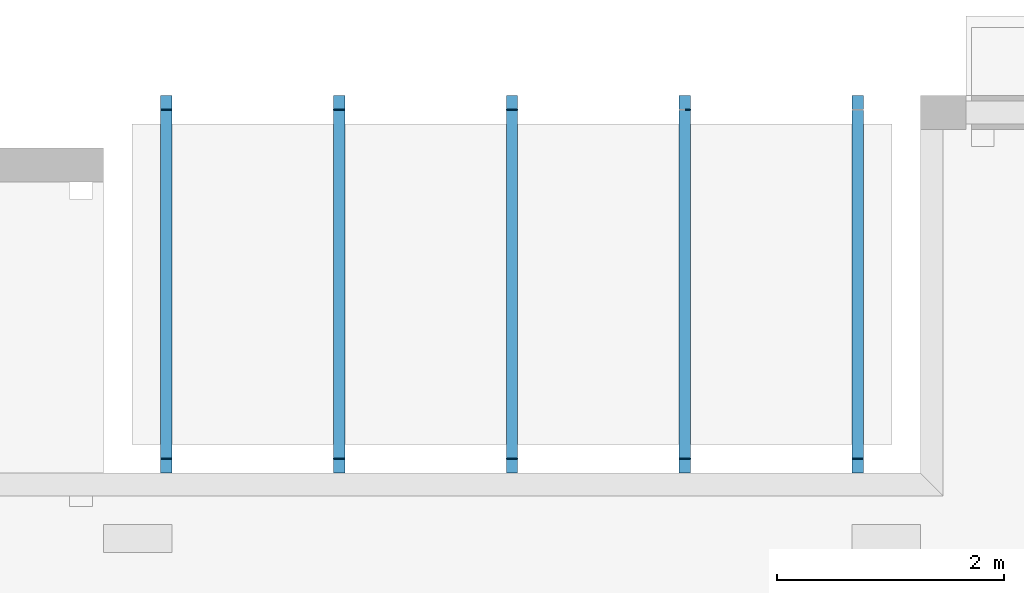
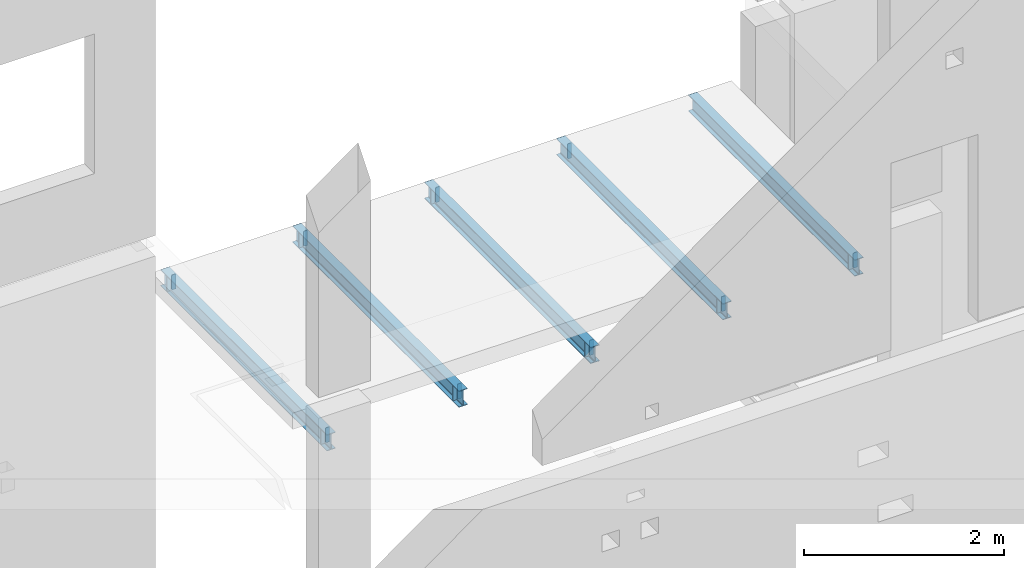
# One storey, part 5 of 7: 22 beams.
"""IFC2X3 building model written with IfcOpenShell, lengths in millimetres."""

from ifc_helpers import new_model, entity, si_unit, converted_unit, derived_unit, money_unit, direction, frame, origin_with_axes, place, context, subcontext, project, spatial, faceted_brep, material, type_object, element, save


model = new_model("IFC2X3")

# Units and contexts
model_context = context("Model", 3, precision=1e-05, world=origin_with_axes(), true_north=direction((0.0, 1.0)))
body_context = subcontext(model_context, "Body", "Model", "MODEL_VIEW", scale=1.0)
ifc_project = project(units=[si_unit("LENGTHUNIT", "METRE", prefix="MILLI"), si_unit("AREAUNIT", "SQUARE_METRE"), si_unit("VOLUMEUNIT", "CUBIC_METRE"), si_unit("ABSORBEDDOSEUNIT", "GRAY"), si_unit("AMOUNTOFSUBSTANCEUNIT", "MOLE"), si_unit("DOSEEQUIVALENTUNIT", "SIEVERT"), si_unit("ELECTRICCAPACITANCEUNIT", "FARAD"), si_unit("ELECTRICCHARGEUNIT", "COULOMB"), si_unit("ELECTRICCONDUCTANCEUNIT", "SIEMENS"), si_unit("ELECTRICCURRENTUNIT", "AMPERE"), si_unit("ELECTRICRESISTANCEUNIT", "OHM"), si_unit("ELECTRICVOLTAGEUNIT", "VOLT"), si_unit("ENERGYUNIT", "JOULE"), si_unit("FORCEUNIT", "NEWTON"), si_unit("FREQUENCYUNIT", "HERTZ"), si_unit("ILLUMINANCEUNIT", "LUX"), si_unit("INDUCTANCEUNIT", "HENRY"), si_unit("LUMINOUSFLUXUNIT", "LUMEN"), si_unit("LUMINOUSINTENSITYUNIT", "CANDELA"), si_unit("MAGNETICFLUXDENSITYUNIT", "TESLA"), si_unit("MAGNETICFLUXUNIT", "WEBER"), si_unit("MASSUNIT", "GRAM"), converted_unit("PLANEANGLEUNIT", "degree", entity("IfcReal", 0.0174532925199433), si_unit("PLANEANGLEUNIT", "RADIAN"), dimensions=[0, 0, 0, 0, 0, 0, 0]), si_unit("POWERUNIT", "WATT"), si_unit("PRESSUREUNIT", "PASCAL"), si_unit("RADIOACTIVITYUNIT", "BECQUEREL"), si_unit("SOLIDANGLEUNIT", "STERADIAN"), si_unit("THERMODYNAMICTEMPERATUREUNIT", "KELVIN"), si_unit("TIMEUNIT", "SECOND"), derived_unit("ACCELERATIONUNIT", [(si_unit("LENGTHUNIT", "METRE", prefix="MILLI"), 1), (si_unit("TIMEUNIT", "SECOND"), -2)]), derived_unit("ANGULARVELOCITYUNIT", [(converted_unit("PLANEANGLEUNIT", "degree", entity("IfcReal", 0.0174532925199433), si_unit("PLANEANGLEUNIT", "RADIAN"), dimensions=[0, 0, 0, 0, 0, 0, 0]), 1), (si_unit("TIMEUNIT", "SECOND"), -1)]), derived_unit("CURVATUREUNIT", [(converted_unit("PLANEANGLEUNIT", "degree", entity("IfcReal", 0.0174532925199433), si_unit("PLANEANGLEUNIT", "RADIAN"), dimensions=[0, 0, 0, 0, 0, 0, 0]), 1), (si_unit("LENGTHUNIT", "METRE", prefix="MILLI"), -1)]), derived_unit("DYNAMICVISCOSITYUNIT", [(si_unit("PRESSUREUNIT", "PASCAL"), 1), (si_unit("TIMEUNIT", "SECOND"), 1)]), derived_unit("HEATFLUXDENSITYUNIT", [(si_unit("POWERUNIT", "WATT"), 1), (si_unit("LENGTHUNIT", "METRE", prefix="MILLI"), -2)]), derived_unit("HEATINGVALUEUNIT", [(si_unit("ENERGYUNIT", "JOULE"), 1), (si_unit("MASSUNIT", "GRAM"), -1)]), derived_unit("INTEGERCOUNTRATEUNIT", [(si_unit("TIMEUNIT", "SECOND"), -1)]), derived_unit("IONCONCENTRATIONUNIT", [(si_unit("MASSUNIT", "GRAM"), 1), (si_unit("VOLUMEUNIT", "CUBIC_METRE"), -1)]), derived_unit("ISOTHERMALMOISTURECAPACITYUNIT", [(si_unit("VOLUMEUNIT", "CUBIC_METRE"), 1), (si_unit("MASSUNIT", "GRAM"), -1)]), derived_unit("KINEMATICVISCOSITYUNIT", [(si_unit("AREAUNIT", "SQUARE_METRE"), 1), (si_unit("TIMEUNIT", "SECOND"), -1)]), derived_unit("LINEARFORCEUNIT", [(si_unit("FORCEUNIT", "NEWTON"), 1), (si_unit("LENGTHUNIT", "METRE", prefix="MILLI"), -1)]), derived_unit("LINEARMOMENTUNIT", [(si_unit("FORCEUNIT", "NEWTON"), 1), (si_unit("LENGTHUNIT", "METRE", prefix="MILLI"), -1)]), derived_unit("LINEARSTIFFNESSUNIT", [(si_unit("FORCEUNIT", "NEWTON"), 1), (si_unit("LENGTHUNIT", "METRE", prefix="MILLI"), -1)]), derived_unit("LINEARVELOCITYUNIT", [(si_unit("LENGTHUNIT", "METRE", prefix="MILLI"), 1), (si_unit("TIMEUNIT", "SECOND"), -1)]), derived_unit("LUMINOUSINTENSITYDISTRIBUTIONUNIT", [(si_unit("LUMINOUSINTENSITYUNIT", "CANDELA"), 1), (si_unit("LUMINOUSFLUXUNIT", "LUMEN"), -1)]), derived_unit("MASSDENSITYUNIT", [(si_unit("MASSUNIT", "GRAM"), 1), (si_unit("VOLUMEUNIT", "CUBIC_METRE"), -1)]), derived_unit("MASSFLOWRATEUNIT", [(si_unit("MASSUNIT", "GRAM"), 1), (si_unit("TIMEUNIT", "SECOND"), -1)]), derived_unit("MASSPERLENGTHUNIT", [(si_unit("MASSUNIT", "GRAM"), 1), (si_unit("LENGTHUNIT", "METRE", prefix="MILLI"), -1)]), derived_unit("MODULUSOFELASTICITYUNIT", [(si_unit("FORCEUNIT", "NEWTON"), 1), (si_unit("AREAUNIT", "SQUARE_METRE"), -1)]), derived_unit("MODULUSOFLINEARSUBGRADEREACTIONUNIT", [(si_unit("FORCEUNIT", "NEWTON"), 1), (si_unit("LENGTHUNIT", "METRE", prefix="MILLI"), -2)]), derived_unit("MODULUSOFROTATIONALSUBGRADEREACTIONUNIT", [(si_unit("FORCEUNIT", "NEWTON"), 1), (si_unit("LENGTHUNIT", "METRE", prefix="MILLI"), 1)]), derived_unit("MODULUSOFSUBGRADEREACTIONUNIT", [(si_unit("FORCEUNIT", "NEWTON"), 1), (si_unit("VOLUMEUNIT", "CUBIC_METRE"), -1)]), derived_unit("MOISTUREDIFFUSIVITYUNIT", [(si_unit("VOLUMEUNIT", "CUBIC_METRE"), 1), (si_unit("TIMEUNIT", "SECOND"), -1)]), derived_unit("MOLECULARWEIGHTUNIT", [(si_unit("MASSUNIT", "GRAM"), 1), (si_unit("AMOUNTOFSUBSTANCEUNIT", "MOLE"), -1)]), derived_unit("PLANARFORCEUNIT", [(si_unit("FORCEUNIT", "NEWTON"), 1), (si_unit("LENGTHUNIT", "METRE", prefix="MILLI"), -2)]), derived_unit("ROTATIONALFREQUENCYUNIT", [(si_unit("TIMEUNIT", "SECOND"), -1)]), derived_unit("ROTATIONALMASSUNIT", [(si_unit("MASSUNIT", "GRAM"), 1), (si_unit("LENGTHUNIT", "METRE", prefix="MILLI"), 2)]), derived_unit("ROTATIONALSTIFFNESSUNIT", [(si_unit("FORCEUNIT", "NEWTON"), 1), (si_unit("LENGTHUNIT", "METRE", prefix="MILLI"), 1), (converted_unit("PLANEANGLEUNIT", "degree", entity("IfcReal", 0.0174532925199433), si_unit("PLANEANGLEUNIT", "RADIAN"), dimensions=[0, 0, 0, 0, 0, 0, 0]), -1)]), derived_unit("SECTIONAREAINTEGRALUNIT", [(si_unit("LENGTHUNIT", "METRE", prefix="MILLI"), 5)]), derived_unit("SECTIONMODULUSUNIT", [(si_unit("LENGTHUNIT", "METRE", prefix="MILLI"), 3)]), derived_unit("SHEARMODULUSUNIT", [(si_unit("FORCEUNIT", "NEWTON"), 1), (si_unit("AREAUNIT", "SQUARE_METRE"), -1)]), derived_unit("SOUNDPOWERUNIT", [(si_unit("ENERGYUNIT", "JOULE"), 1), (si_unit("TIMEUNIT", "SECOND"), -1)]), derived_unit("SPECIFICHEATCAPACITYUNIT", [(si_unit("FORCEUNIT", "NEWTON"), 1), (si_unit("MASSUNIT", "GRAM"), -1), (si_unit("THERMODYNAMICTEMPERATUREUNIT", "KELVIN"), -1)]), derived_unit("TEMPERATUREGRADIENTUNIT", [(si_unit("THERMODYNAMICTEMPERATUREUNIT", "KELVIN"), 1), (si_unit("LENGTHUNIT", "METRE", prefix="MILLI"), -1)]), derived_unit("THERMALADMITTANCEUNIT", [(si_unit("POWERUNIT", "WATT"), 1), (si_unit("AREAUNIT", "SQUARE_METRE"), -1), (si_unit("THERMODYNAMICTEMPERATUREUNIT", "KELVIN"), -1)]), derived_unit("THERMALCONDUCTANCEUNIT", [(si_unit("POWERUNIT", "WATT"), 1), (si_unit("LENGTHUNIT", "METRE", prefix="MILLI"), -1), (si_unit("THERMODYNAMICTEMPERATUREUNIT", "KELVIN"), -1)]), derived_unit("THERMALEXPANSIONCOEFFICIENTUNIT", [(si_unit("THERMODYNAMICTEMPERATUREUNIT", "KELVIN"), -1)]), derived_unit("THERMALRESISTANCEUNIT", [(si_unit("AREAUNIT", "SQUARE_METRE"), 1), (si_unit("POWERUNIT", "WATT"), -1)]), derived_unit("THERMALTRANSMITTANCEUNIT", [(si_unit("POWERUNIT", "WATT"), 1), (si_unit("AREAUNIT", "SQUARE_METRE"), -1), (si_unit("THERMODYNAMICTEMPERATUREUNIT", "KELVIN"), -1)]), derived_unit("TORQUEUNIT", [(si_unit("FORCEUNIT", "NEWTON"), 1), (si_unit("LENGTHUNIT", "METRE", prefix="MILLI"), 1)]), derived_unit("VAPORPERMEABILITYUNIT", [(si_unit("MASSUNIT", "GRAM"), 1), (si_unit("TIMEUNIT", "SECOND"), -1)]), derived_unit("VOLUMETRICFLOWRATEUNIT", [(si_unit("VOLUMEUNIT", "CUBIC_METRE"), 1), (si_unit("TIMEUNIT", "SECOND"), -1)]), derived_unit("WARPINGCONSTANTUNIT", [(si_unit("LENGTHUNIT", "METRE", prefix="MILLI"), 6)]), derived_unit("WARPINGMOMENTUNIT", [(si_unit("FORCEUNIT", "NEWTON"), 1), (si_unit("LENGTHUNIT", "METRE", prefix="MILLI"), 2)]), money_unit("USD")], contexts=[model_context])

# Site, building, storey
site_placement = place(None, origin_with_axes())
site = spatial("IfcSite", under=ifc_project, at=site_placement, CompositionType="ELEMENT")
building_placement = place(site_placement, origin_with_axes())
building = spatial("IfcBuilding", under=site, at=building_placement, Name="1", CompositionType="ELEMENT")
storey_placement = place(building_placement, frame((0.0, 0.0, -4900.0), z_axis=(0.0, 0.0, 1.0), x_axis=(1.0, 0.0, 0.0)))
storey = spatial("IfcBuildingStorey", under=building, at=storey_placement, Name="-2", CompositionType="ELEMENT", Elevation=-4900.0)

# Beams
ifc_material = material()
beam_type = type_object("IfcBeamType", PredefinedType="BEAM")
placement = place(storey_placement, frame((0.0, 0.0, 4900.0), z_axis=(0.0, 0.0, 1.0), x_axis=(1.0, 0.0, 0.0)))
element("IfcBeam", 1, at=placement, inside=storey, type_object=beam_type, material=ifc_material, context=body_context, shape_type="Brep", body=[
    faceted_brep([(9475.0, 10060.0, -1400.0), (9475.0, 6740.0, -1400.0), (9475.0, 6740.0, -1392.0), (9475.0, 10060.0, -1392.0), (9511.25, 6740.0, -1392.0), (9511.25, 10060.0, -1392.0), (9515.46, 6740.0, -1391.16), (9515.46, 10060.0, -1391.16), (9519.03, 6740.0, -1388.78), (9519.03, 10060.0, -1388.78), (9521.41, 6740.0, -1385.21), (9521.41, 10060.0, -1385.21), (9522.25, 6740.0, -1381.0), (9522.25, 10060.0, -1381.0), (9522.25, 10060.0, -1219.0), (9521.41, 10060.0, -1214.79), (9519.03, 10060.0, -1211.22), (9515.46, 10060.0, -1208.84), (9511.25, 10060.0, -1208.0), (9475.0, 10060.0, -1208.0), (9475.0, 10060.0, -1200.0), (9575.0, 10060.0, -1200.0), (9575.0, 10060.0, -1208.0), (9538.75, 10060.0, -1208.0), (9534.54, 10060.0, -1208.84), (9530.97, 10060.0, -1211.22), (9528.59, 10060.0, -1214.79), (9527.75, 10060.0, -1219.0), (9527.75, 10060.0, -1381.0), (9528.59, 10060.0, -1385.21), (9530.97, 10060.0, -1388.78), (9534.54, 10060.0, -1391.16), (9538.75, 10060.0, -1392.0), (9575.0, 10060.0, -1392.0), (9575.0, 10060.0, -1400.0), (9575.0, 6740.0, -1400.0), (9575.0, 6740.0, -1392.0), (9538.75, 6740.0, -1392.0), (9534.54, 6740.0, -1391.16), (9530.97, 6740.0, -1388.78), (9528.59, 6740.0, -1385.21), (9527.75, 6740.0, -1381.0), (9527.75, 6740.0, -1219.0), (9528.59, 6740.0, -1214.79), (9530.97, 6740.0, -1211.22), (9534.54, 6740.0, -1208.84), (9538.75, 6740.0, -1208.0), (9575.0, 6740.0, -1208.0), (9575.0, 6740.0, -1200.0), (9475.0, 6740.0, -1200.0), (9475.0, 6740.0, -1208.0), (9511.25, 6740.0, -1208.0), (9515.46, 6740.0, -1208.84), (9519.03, 6740.0, -1211.22), (9521.41, 6740.0, -1214.79), (9522.25, 6740.0, -1219.0)], [[[0, 1, 2, 3]], [[3, 2, 4, 5]], [[5, 4, 6, 7]], [[7, 6, 8, 9]], [[9, 8, 10, 11]], [[11, 10, 12, 13]], [[0, 3, 5, 7, 9, 11, 13, 14, 15, 16, 17, 18, 19, 20, 21, 22, 23, 24, 25, 26, 27, 28, 29, 30, 31, 32, 33, 34]], [[35, 36, 37, 38, 39, 40, 41, 42, 43, 44, 45, 46, 47, 48, 49, 50, 51, 52, 53, 54, 55, 12, 10, 8, 6, 4, 2, 1]], [[13, 12, 55, 14]], [[14, 55, 54, 15]], [[15, 54, 53, 16]], [[16, 53, 52, 17]], [[17, 52, 51, 18]], [[18, 51, 50, 19]], [[19, 50, 49, 20]], [[20, 49, 48, 21]], [[21, 48, 47, 22]], [[22, 47, 46, 23]], [[23, 46, 45, 24]], [[24, 45, 44, 25]], [[25, 44, 43, 26]], [[26, 43, 42, 27]], [[27, 42, 41, 28]], [[28, 41, 40, 29]], [[29, 40, 39, 30]], [[30, 39, 38, 31]], [[31, 38, 37, 32]], [[32, 37, 36, 33]], [[33, 36, 35, 34]], [[34, 35, 1, 0]]]),
])
element("IfcBeam", 2, at=placement, inside=storey, type_object=beam_type, material=ifc_material, context=body_context, shape_type="Brep", body=[
    faceted_brep([(9527.0, 6860.0, -1382.0), (9538.0, 6860.0, -1392.0), (9575.0, 6860.0, -1392.0), (9575.0, 6860.0, -1208.0), (9537.0, 6860.0, -1208.0), (9527.0, 6860.0, -1218.0), (9538.0, 6870.0, -1392.0), (9527.0, 6870.0, -1382.0), (9527.0, 6870.0, -1218.0), (9537.0, 6870.0, -1208.0), (9575.0, 6870.0, -1208.0), (9575.0, 6870.0, -1392.0)], [[[0, 1, 2, 3, 4, 5]], [[6, 7, 8, 9, 10, 11]], [[3, 2, 11, 10]], [[6, 11, 2, 1]], [[9, 4, 3, 10]], [[8, 7, 0, 5]], [[7, 6, 1, 0]], [[9, 8, 5, 4]]]),
])
element("IfcBeam", 3, at=placement, inside=storey, type_object=beam_type, material=ifc_material, context=body_context, shape_type="Brep", body=[
    faceted_brep([(9512.0, 6860.0, -1392.0), (9523.0, 6860.0, -1382.0), (9523.0, 6860.0, -1218.0), (9513.0, 6860.0, -1208.0), (9475.0, 6860.0, -1208.0), (9475.0, 6860.0, -1392.0), (9523.0, 6870.0, -1382.0), (9512.0, 6870.0, -1392.0), (9475.0, 6870.0, -1392.0), (9475.0, 6870.0, -1208.0), (9513.0, 6870.0, -1208.0), (9523.0, 6870.0, -1218.0)], [[[0, 1, 2, 3, 4, 5]], [[6, 7, 8, 9, 10, 11]], [[0, 5, 8, 7]], [[3, 10, 9, 4]], [[9, 8, 5, 4]], [[7, 6, 1, 0]], [[6, 11, 2, 1]], [[11, 10, 3, 2]]]),
])
element("IfcBeam", 4, at=placement, inside=storey, type_object=beam_type, material=ifc_material, context=body_context, shape_type="Brep", body=[
    faceted_brep([(9527.0, 9930.0, -1382.0), (9538.0, 9930.0, -1392.0), (9575.0, 9930.0, -1392.0), (9575.0, 9930.0, -1208.0), (9537.0, 9930.0, -1208.0), (9527.0, 9930.0, -1218.0), (9538.0, 9940.0, -1392.0), (9527.0, 9940.0, -1382.0), (9527.0, 9940.0, -1218.0), (9537.0, 9940.0, -1208.0), (9575.0, 9940.0, -1208.0), (9575.0, 9940.0, -1392.0)], [[[0, 1, 2, 3, 4, 5]], [[6, 7, 8, 9, 10, 11]], [[3, 2, 11, 10]], [[6, 11, 2, 1]], [[9, 4, 3, 10]], [[8, 7, 0, 5]], [[7, 6, 1, 0]], [[9, 8, 5, 4]]]),
])
element("IfcBeam", 5, at=placement, inside=storey, type_object=beam_type, material=ifc_material, context=body_context, shape_type="Brep", body=[
    faceted_brep([(9512.0, 9930.0, -1392.0), (9523.0, 9930.0, -1382.0), (9523.0, 9930.0, -1218.0), (9513.0, 9930.0, -1208.0), (9475.0, 9930.0, -1208.0), (9475.0, 9930.0, -1392.0), (9523.0, 9940.0, -1382.0), (9512.0, 9940.0, -1392.0), (9475.0, 9940.0, -1392.0), (9475.0, 9940.0, -1208.0), (9513.0, 9940.0, -1208.0), (9523.0, 9940.0, -1218.0)], [[[0, 1, 2, 3, 4, 5]], [[6, 7, 8, 9, 10, 11]], [[0, 5, 8, 7]], [[3, 10, 9, 4]], [[9, 8, 5, 4]], [[7, 6, 1, 0]], [[6, 11, 2, 1]], [[11, 10, 3, 2]]]),
])
element("IfcBeam", 6, at=placement, inside=storey, type_object=beam_type, material=ifc_material, context=body_context, shape_type="Brep", body=[
    faceted_brep([(10995.0, 10060.0, -1400.0), (10995.0, 6740.0, -1400.0), (10995.0, 6740.0, -1392.0), (10995.0, 10060.0, -1392.0), (11031.25, 6740.0, -1392.0), (11031.25, 10060.0, -1392.0), (11035.46, 6740.0, -1391.16), (11035.46, 10060.0, -1391.16), (11039.03, 6740.0, -1388.78), (11039.03, 10060.0, -1388.78), (11041.41, 6740.0, -1385.21), (11041.41, 10060.0, -1385.21), (11042.25, 6740.0, -1381.0), (11042.25, 10060.0, -1381.0), (11042.25, 10060.0, -1219.0), (11041.41, 10060.0, -1214.79), (11039.03, 10060.0, -1211.22), (11035.46, 10060.0, -1208.84), (11031.25, 10060.0, -1208.0), (10995.0, 10060.0, -1208.0), (10995.0, 10060.0, -1200.0), (11095.0, 10060.0, -1200.0), (11095.0, 10060.0, -1208.0), (11058.75, 10060.0, -1208.0), (11054.54, 10060.0, -1208.84), (11050.97, 10060.0, -1211.22), (11048.59, 10060.0, -1214.79), (11047.75, 10060.0, -1219.0), (11047.75, 10060.0, -1381.0), (11048.59, 10060.0, -1385.21), (11050.97, 10060.0, -1388.78), (11054.54, 10060.0, -1391.16), (11058.75, 10060.0, -1392.0), (11095.0, 10060.0, -1392.0), (11095.0, 10060.0, -1400.0), (11095.0, 6740.0, -1400.0), (11095.0, 6740.0, -1392.0), (11058.75, 6740.0, -1392.0), (11054.54, 6740.0, -1391.16), (11050.97, 6740.0, -1388.78), (11048.59, 6740.0, -1385.21), (11047.75, 6740.0, -1381.0), (11047.75, 6740.0, -1219.0), (11048.59, 6740.0, -1214.79), (11050.97, 6740.0, -1211.22), (11054.54, 6740.0, -1208.84), (11058.75, 6740.0, -1208.0), (11095.0, 6740.0, -1208.0), (11095.0, 6740.0, -1200.0), (10995.0, 6740.0, -1200.0), (10995.0, 6740.0, -1208.0), (11031.25, 6740.0, -1208.0), (11035.46, 6740.0, -1208.84), (11039.03, 6740.0, -1211.22), (11041.41, 6740.0, -1214.79), (11042.25, 6740.0, -1219.0)], [[[0, 1, 2, 3]], [[3, 2, 4, 5]], [[5, 4, 6, 7]], [[7, 6, 8, 9]], [[9, 8, 10, 11]], [[11, 10, 12, 13]], [[0, 3, 5, 7, 9, 11, 13, 14, 15, 16, 17, 18, 19, 20, 21, 22, 23, 24, 25, 26, 27, 28, 29, 30, 31, 32, 33, 34]], [[35, 36, 37, 38, 39, 40, 41, 42, 43, 44, 45, 46, 47, 48, 49, 50, 51, 52, 53, 54, 55, 12, 10, 8, 6, 4, 2, 1]], [[13, 12, 55, 14]], [[14, 55, 54, 15]], [[15, 54, 53, 16]], [[16, 53, 52, 17]], [[17, 52, 51, 18]], [[18, 51, 50, 19]], [[19, 50, 49, 20]], [[20, 49, 48, 21]], [[21, 48, 47, 22]], [[22, 47, 46, 23]], [[23, 46, 45, 24]], [[24, 45, 44, 25]], [[25, 44, 43, 26]], [[26, 43, 42, 27]], [[27, 42, 41, 28]], [[28, 41, 40, 29]], [[29, 40, 39, 30]], [[30, 39, 38, 31]], [[31, 38, 37, 32]], [[32, 37, 36, 33]], [[33, 36, 35, 34]], [[34, 35, 1, 0]]]),
])
element("IfcBeam", 7, at=placement, inside=storey, type_object=beam_type, material=ifc_material, context=body_context, shape_type="Brep", body=[
    faceted_brep([(11047.0, 6860.0, -1382.0), (11058.0, 6860.0, -1392.0), (11095.0, 6860.0, -1392.0), (11095.0, 6860.0, -1208.0), (11057.0, 6860.0, -1208.0), (11047.0, 6860.0, -1218.0), (11058.0, 6870.0, -1392.0), (11047.0, 6870.0, -1382.0), (11047.0, 6870.0, -1218.0), (11057.0, 6870.0, -1208.0), (11095.0, 6870.0, -1208.0), (11095.0, 6870.0, -1392.0)], [[[0, 1, 2, 3, 4, 5]], [[6, 7, 8, 9, 10, 11]], [[3, 2, 11, 10]], [[6, 11, 2, 1]], [[9, 4, 3, 10]], [[8, 7, 0, 5]], [[7, 6, 1, 0]], [[9, 8, 5, 4]]]),
])
element("IfcBeam", 8, at=placement, inside=storey, type_object=beam_type, material=ifc_material, context=body_context, shape_type="Brep", body=[
    faceted_brep([(11032.0, 6860.0, -1392.0), (11043.0, 6860.0, -1382.0), (11043.0, 6860.0, -1218.0), (11033.0, 6860.0, -1208.0), (10995.0, 6860.0, -1208.0), (10995.0, 6860.0, -1392.0), (11043.0, 6870.0, -1382.0), (11032.0, 6870.0, -1392.0), (10995.0, 6870.0, -1392.0), (10995.0, 6870.0, -1208.0), (11033.0, 6870.0, -1208.0), (11043.0, 6870.0, -1218.0)], [[[0, 1, 2, 3, 4, 5]], [[6, 7, 8, 9, 10, 11]], [[0, 5, 8, 7]], [[3, 10, 9, 4]], [[9, 8, 5, 4]], [[7, 6, 1, 0]], [[6, 11, 2, 1]], [[11, 10, 3, 2]]]),
])
element("IfcBeam", 9, at=placement, inside=storey, type_object=beam_type, material=ifc_material, context=body_context, shape_type="Brep", body=[
    faceted_brep([(11047.0, 9930.0, -1382.0), (11058.0, 9930.0, -1392.0), (11095.0, 9930.0, -1392.0), (11095.0, 9930.0, -1208.0), (11057.0, 9930.0, -1208.0), (11047.0, 9930.0, -1218.0), (11058.0, 9940.0, -1392.0), (11047.0, 9940.0, -1382.0), (11047.0, 9940.0, -1218.0), (11057.0, 9940.0, -1208.0), (11095.0, 9940.0, -1208.0), (11095.0, 9940.0, -1392.0)], [[[0, 1, 2, 3, 4, 5]], [[6, 7, 8, 9, 10, 11]], [[3, 2, 11, 10]], [[6, 11, 2, 1]], [[9, 4, 3, 10]], [[8, 7, 0, 5]], [[7, 6, 1, 0]], [[9, 8, 5, 4]]]),
])
element("IfcBeam", 10, at=placement, inside=storey, type_object=beam_type, material=ifc_material, context=body_context, shape_type="Brep", body=[
    faceted_brep([(11032.0, 9930.0, -1392.0), (11043.0, 9930.0, -1382.0), (11043.0, 9930.0, -1218.0), (11033.0, 9930.0, -1208.0), (10995.0, 9930.0, -1208.0), (10995.0, 9930.0, -1392.0), (11043.0, 9940.0, -1382.0), (11032.0, 9940.0, -1392.0), (10995.0, 9940.0, -1392.0), (10995.0, 9940.0, -1208.0), (11033.0, 9940.0, -1208.0), (11043.0, 9940.0, -1218.0)], [[[0, 1, 2, 3, 4, 5]], [[6, 7, 8, 9, 10, 11]], [[0, 5, 8, 7]], [[3, 10, 9, 4]], [[9, 8, 5, 4]], [[7, 6, 1, 0]], [[6, 11, 2, 1]], [[11, 10, 3, 2]]]),
])
element("IfcBeam", 11, at=placement, inside=storey, type_object=beam_type, material=ifc_material, context=body_context, shape_type="Brep", body=[
    faceted_brep([(12515.0, 10060.0, -1400.0), (12515.0, 6740.0, -1400.0), (12515.0, 6740.0, -1392.0), (12515.0, 10060.0, -1392.0), (12551.25, 6740.0, -1392.0), (12551.25, 10060.0, -1392.0), (12555.46, 6740.0, -1391.16), (12555.46, 10060.0, -1391.16), (12559.03, 6740.0, -1388.78), (12559.03, 10060.0, -1388.78), (12561.41, 6740.0, -1385.21), (12561.41, 10060.0, -1385.21), (12562.25, 6740.0, -1381.0), (12562.25, 10060.0, -1381.0), (12562.25, 10060.0, -1219.0), (12561.41, 10060.0, -1214.79), (12559.03, 10060.0, -1211.22), (12555.46, 10060.0, -1208.84), (12551.25, 10060.0, -1208.0), (12515.0, 10060.0, -1208.0), (12515.0, 10060.0, -1200.0), (12615.0, 10060.0, -1200.0), (12615.0, 10060.0, -1208.0), (12578.75, 10060.0, -1208.0), (12574.54, 10060.0, -1208.84), (12570.97, 10060.0, -1211.22), (12568.59, 10060.0, -1214.79), (12567.75, 10060.0, -1219.0), (12567.75, 10060.0, -1381.0), (12568.59, 10060.0, -1385.21), (12570.97, 10060.0, -1388.78), (12574.54, 10060.0, -1391.16), (12578.75, 10060.0, -1392.0), (12615.0, 10060.0, -1392.0), (12615.0, 10060.0, -1400.0), (12615.0, 6740.0, -1400.0), (12615.0, 6740.0, -1392.0), (12578.75, 6740.0, -1392.0), (12574.54, 6740.0, -1391.16), (12570.97, 6740.0, -1388.78), (12568.59, 6740.0, -1385.21), (12567.75, 6740.0, -1381.0), (12567.75, 6740.0, -1219.0), (12568.59, 6740.0, -1214.79), (12570.97, 6740.0, -1211.22), (12574.54, 6740.0, -1208.84), (12578.75, 6740.0, -1208.0), (12615.0, 6740.0, -1208.0), (12615.0, 6740.0, -1200.0), (12515.0, 6740.0, -1200.0), (12515.0, 6740.0, -1208.0), (12551.25, 6740.0, -1208.0), (12555.46, 6740.0, -1208.84), (12559.03, 6740.0, -1211.22), (12561.41, 6740.0, -1214.79), (12562.25, 6740.0, -1219.0)], [[[0, 1, 2, 3]], [[3, 2, 4, 5]], [[5, 4, 6, 7]], [[7, 6, 8, 9]], [[9, 8, 10, 11]], [[11, 10, 12, 13]], [[0, 3, 5, 7, 9, 11, 13, 14, 15, 16, 17, 18, 19, 20, 21, 22, 23, 24, 25, 26, 27, 28, 29, 30, 31, 32, 33, 34]], [[35, 36, 37, 38, 39, 40, 41, 42, 43, 44, 45, 46, 47, 48, 49, 50, 51, 52, 53, 54, 55, 12, 10, 8, 6, 4, 2, 1]], [[13, 12, 55, 14]], [[14, 55, 54, 15]], [[15, 54, 53, 16]], [[16, 53, 52, 17]], [[17, 52, 51, 18]], [[18, 51, 50, 19]], [[19, 50, 49, 20]], [[20, 49, 48, 21]], [[21, 48, 47, 22]], [[22, 47, 46, 23]], [[23, 46, 45, 24]], [[24, 45, 44, 25]], [[25, 44, 43, 26]], [[26, 43, 42, 27]], [[27, 42, 41, 28]], [[28, 41, 40, 29]], [[29, 40, 39, 30]], [[30, 39, 38, 31]], [[31, 38, 37, 32]], [[32, 37, 36, 33]], [[33, 36, 35, 34]], [[34, 35, 1, 0]]]),
])
element("IfcBeam", 12, at=placement, inside=storey, type_object=beam_type, material=ifc_material, context=body_context, shape_type="Brep", body=[
    faceted_brep([(12567.0, 6860.0, -1382.0), (12578.0, 6860.0, -1392.0), (12615.0, 6860.0, -1392.0), (12615.0, 6860.0, -1208.0), (12577.0, 6860.0, -1208.0), (12567.0, 6860.0, -1218.0), (12578.0, 6870.0, -1392.0), (12567.0, 6870.0, -1382.0), (12567.0, 6870.0, -1218.0), (12577.0, 6870.0, -1208.0), (12615.0, 6870.0, -1208.0), (12615.0, 6870.0, -1392.0)], [[[0, 1, 2, 3, 4, 5]], [[6, 7, 8, 9, 10, 11]], [[3, 2, 11, 10]], [[6, 11, 2, 1]], [[9, 4, 3, 10]], [[8, 7, 0, 5]], [[7, 6, 1, 0]], [[9, 8, 5, 4]]]),
])
element("IfcBeam", 13, at=placement, inside=storey, type_object=beam_type, material=ifc_material, context=body_context, shape_type="Brep", body=[
    faceted_brep([(12552.0, 6860.0, -1392.0), (12563.0, 6860.0, -1382.0), (12563.0, 6860.0, -1218.0), (12553.0, 6860.0, -1208.0), (12515.0, 6860.0, -1208.0), (12515.0, 6860.0, -1392.0), (12563.0, 6870.0, -1382.0), (12552.0, 6870.0, -1392.0), (12515.0, 6870.0, -1392.0), (12515.0, 6870.0, -1208.0), (12553.0, 6870.0, -1208.0), (12563.0, 6870.0, -1218.0)], [[[0, 1, 2, 3, 4, 5]], [[6, 7, 8, 9, 10, 11]], [[0, 5, 8, 7]], [[3, 10, 9, 4]], [[9, 8, 5, 4]], [[7, 6, 1, 0]], [[6, 11, 2, 1]], [[11, 10, 3, 2]]]),
])
element("IfcBeam", 14, at=placement, inside=storey, type_object=beam_type, material=ifc_material, context=body_context, shape_type="Brep", body=[
    faceted_brep([(12567.0, 9930.0, -1382.0), (12578.0, 9930.0, -1392.0), (12615.0, 9930.0, -1392.0), (12615.0, 9930.0, -1208.0), (12577.0, 9930.0, -1208.0), (12567.0, 9930.0, -1218.0), (12578.0, 9940.0, -1392.0), (12567.0, 9940.0, -1382.0), (12567.0, 9940.0, -1218.0), (12577.0, 9940.0, -1208.0), (12615.0, 9940.0, -1208.0), (12615.0, 9940.0, -1392.0)], [[[0, 1, 2, 3, 4, 5]], [[6, 7, 8, 9, 10, 11]], [[3, 2, 11, 10]], [[6, 11, 2, 1]], [[9, 4, 3, 10]], [[8, 7, 0, 5]], [[7, 6, 1, 0]], [[9, 8, 5, 4]]]),
])
element("IfcBeam", 15, at=placement, inside=storey, type_object=beam_type, material=ifc_material, context=body_context, shape_type="Brep", body=[
    faceted_brep([(12552.0, 9930.0, -1392.0), (12563.0, 9930.0, -1382.0), (12563.0, 9930.0, -1218.0), (12553.0, 9930.0, -1208.0), (12515.0, 9930.0, -1208.0), (12515.0, 9930.0, -1392.0), (12563.0, 9940.0, -1382.0), (12552.0, 9940.0, -1392.0), (12515.0, 9940.0, -1392.0), (12515.0, 9940.0, -1208.0), (12553.0, 9940.0, -1208.0), (12563.0, 9940.0, -1218.0)], [[[0, 1, 2, 3, 4, 5]], [[6, 7, 8, 9, 10, 11]], [[0, 5, 8, 7]], [[3, 10, 9, 4]], [[9, 8, 5, 4]], [[7, 6, 1, 0]], [[6, 11, 2, 1]], [[11, 10, 3, 2]]]),
])
element("IfcBeam", 16, at=placement, inside=storey, type_object=beam_type, material=ifc_material, context=body_context, shape_type="Brep", body=[
    faceted_brep([(14035.0, 10060.0, -1400.0), (14035.0, 6740.0, -1400.0), (14035.0, 6740.0, -1392.0), (14035.0, 10060.0, -1392.0), (14071.25, 6740.0, -1392.0), (14071.25, 10060.0, -1392.0), (14075.46, 6740.0, -1391.16), (14075.46, 10060.0, -1391.16), (14079.03, 6740.0, -1388.78), (14079.03, 10060.0, -1388.78), (14081.41, 6740.0, -1385.21), (14081.41, 10060.0, -1385.21), (14082.25, 6740.0, -1381.0), (14082.25, 10060.0, -1381.0), (14082.25, 10060.0, -1219.0), (14081.41, 10060.0, -1214.79), (14079.03, 10060.0, -1211.22), (14075.46, 10060.0, -1208.84), (14071.25, 10060.0, -1208.0), (14035.0, 10060.0, -1208.0), (14035.0, 10060.0, -1200.0), (14135.0, 10060.0, -1200.0), (14135.0, 10060.0, -1208.0), (14098.75, 10060.0, -1208.0), (14094.54, 10060.0, -1208.84), (14090.97, 10060.0, -1211.22), (14088.59, 10060.0, -1214.79), (14087.75, 10060.0, -1219.0), (14087.75, 10060.0, -1381.0), (14088.59, 10060.0, -1385.21), (14090.97, 10060.0, -1388.78), (14094.54, 10060.0, -1391.16), (14098.75, 10060.0, -1392.0), (14135.0, 10060.0, -1392.0), (14135.0, 10060.0, -1400.0), (14135.0, 6740.0, -1400.0), (14135.0, 6740.0, -1392.0), (14098.75, 6740.0, -1392.0), (14094.54, 6740.0, -1391.16), (14090.97, 6740.0, -1388.78), (14088.59, 6740.0, -1385.21), (14087.75, 6740.0, -1381.0), (14087.75, 6740.0, -1219.0), (14088.59, 6740.0, -1214.79), (14090.97, 6740.0, -1211.22), (14094.54, 6740.0, -1208.84), (14098.75, 6740.0, -1208.0), (14135.0, 6740.0, -1208.0), (14135.0, 6740.0, -1200.0), (14035.0, 6740.0, -1200.0), (14035.0, 6740.0, -1208.0), (14071.25, 6740.0, -1208.0), (14075.46, 6740.0, -1208.84), (14079.03, 6740.0, -1211.22), (14081.41, 6740.0, -1214.79), (14082.25, 6740.0, -1219.0)], [[[0, 1, 2, 3]], [[3, 2, 4, 5]], [[5, 4, 6, 7]], [[7, 6, 8, 9]], [[9, 8, 10, 11]], [[11, 10, 12, 13]], [[0, 3, 5, 7, 9, 11, 13, 14, 15, 16, 17, 18, 19, 20, 21, 22, 23, 24, 25, 26, 27, 28, 29, 30, 31, 32, 33, 34]], [[35, 36, 37, 38, 39, 40, 41, 42, 43, 44, 45, 46, 47, 48, 49, 50, 51, 52, 53, 54, 55, 12, 10, 8, 6, 4, 2, 1]], [[13, 12, 55, 14]], [[14, 55, 54, 15]], [[15, 54, 53, 16]], [[16, 53, 52, 17]], [[17, 52, 51, 18]], [[18, 51, 50, 19]], [[19, 50, 49, 20]], [[20, 49, 48, 21]], [[21, 48, 47, 22]], [[22, 47, 46, 23]], [[23, 46, 45, 24]], [[24, 45, 44, 25]], [[25, 44, 43, 26]], [[26, 43, 42, 27]], [[27, 42, 41, 28]], [[28, 41, 40, 29]], [[29, 40, 39, 30]], [[30, 39, 38, 31]], [[31, 38, 37, 32]], [[32, 37, 36, 33]], [[33, 36, 35, 34]], [[34, 35, 1, 0]]]),
])
element("IfcBeam", 17, at=placement, inside=storey, type_object=beam_type, material=ifc_material, context=body_context, shape_type="Brep", body=[
    faceted_brep([(14087.0, 6860.0, -1382.0), (14098.0, 6860.0, -1392.0), (14135.0, 6860.0, -1392.0), (14135.0, 6860.0, -1208.0), (14097.0, 6860.0, -1208.0), (14087.0, 6860.0, -1218.0), (14098.0, 6870.0, -1392.0), (14087.0, 6870.0, -1382.0), (14087.0, 6870.0, -1218.0), (14097.0, 6870.0, -1208.0), (14135.0, 6870.0, -1208.0), (14135.0, 6870.0, -1392.0)], [[[0, 1, 2, 3, 4, 5]], [[6, 7, 8, 9, 10, 11]], [[3, 2, 11, 10]], [[6, 11, 2, 1]], [[9, 4, 3, 10]], [[8, 7, 0, 5]], [[7, 6, 1, 0]], [[9, 8, 5, 4]]]),
])
element("IfcBeam", 18, at=placement, inside=storey, type_object=beam_type, material=ifc_material, context=body_context, shape_type="Brep", body=[
    faceted_brep([(14072.0, 6860.0, -1392.0), (14083.0, 6860.0, -1382.0), (14083.0, 6860.0, -1218.0), (14073.0, 6860.0, -1208.0), (14035.0, 6860.0, -1208.0), (14035.0, 6860.0, -1392.0), (14083.0, 6870.0, -1382.0), (14072.0, 6870.0, -1392.0), (14035.0, 6870.0, -1392.0), (14035.0, 6870.0, -1208.0), (14073.0, 6870.0, -1208.0), (14083.0, 6870.0, -1218.0)], [[[0, 1, 2, 3, 4, 5]], [[6, 7, 8, 9, 10, 11]], [[0, 5, 8, 7]], [[3, 10, 9, 4]], [[9, 8, 5, 4]], [[7, 6, 1, 0]], [[6, 11, 2, 1]], [[11, 10, 3, 2]]]),
])
element("IfcBeam", 19, at=placement, inside=storey, type_object=beam_type, material=ifc_material, context=body_context, shape_type="Brep", body=[
    faceted_brep([(14087.0, 9930.0, -1382.0), (14098.0, 9930.0, -1392.0), (14135.0, 9930.0, -1392.0), (14135.0, 9930.0, -1208.0), (14097.0, 9930.0, -1208.0), (14087.0, 9930.0, -1218.0), (14098.0, 9940.0, -1392.0), (14087.0, 9940.0, -1382.0), (14087.0, 9940.0, -1218.0), (14097.0, 9940.0, -1208.0), (14135.0, 9940.0, -1208.0), (14135.0, 9940.0, -1392.0)], [[[0, 1, 2, 3, 4, 5]], [[6, 7, 8, 9, 10, 11]], [[3, 2, 11, 10]], [[6, 11, 2, 1]], [[9, 4, 3, 10]], [[8, 7, 0, 5]], [[7, 6, 1, 0]], [[9, 8, 5, 4]]]),
])
element("IfcBeam", 20, at=placement, inside=storey, type_object=beam_type, material=ifc_material, context=body_context, shape_type="Brep", body=[
    faceted_brep([(15555.0, 10060.0, -1400.0), (15555.0, 6740.0, -1400.0), (15555.0, 6740.0, -1392.0), (15555.0, 10060.0, -1392.0), (15591.25, 6740.0, -1392.0), (15591.25, 10060.0, -1392.0), (15595.46, 6740.0, -1391.16), (15595.46, 10060.0, -1391.16), (15599.03, 6740.0, -1388.78), (15599.03, 10060.0, -1388.78), (15601.41, 6740.0, -1385.21), (15601.41, 10060.0, -1385.21), (15602.25, 6740.0, -1381.0), (15602.25, 10060.0, -1381.0), (15602.25, 10060.0, -1219.0), (15601.41, 10060.0, -1214.79), (15599.03, 10060.0, -1211.22), (15595.46, 10060.0, -1208.84), (15591.25, 10060.0, -1208.0), (15555.0, 10060.0, -1208.0), (15555.0, 10060.0, -1200.0), (15655.0, 10060.0, -1200.0), (15655.0, 10060.0, -1208.0), (15618.75, 10060.0, -1208.0), (15614.54, 10060.0, -1208.84), (15610.97, 10060.0, -1211.22), (15608.59, 10060.0, -1214.79), (15607.75, 10060.0, -1219.0), (15607.75, 10060.0, -1381.0), (15608.59, 10060.0, -1385.21), (15610.97, 10060.0, -1388.78), (15614.54, 10060.0, -1391.16), (15618.75, 10060.0, -1392.0), (15655.0, 10060.0, -1392.0), (15655.0, 10060.0, -1400.0), (15655.0, 6740.0, -1400.0), (15655.0, 6740.0, -1392.0), (15618.75, 6740.0, -1392.0), (15614.54, 6740.0, -1391.16), (15610.97, 6740.0, -1388.78), (15608.59, 6740.0, -1385.21), (15607.75, 6740.0, -1381.0), (15607.75, 6740.0, -1219.0), (15608.59, 6740.0, -1214.79), (15610.97, 6740.0, -1211.22), (15614.54, 6740.0, -1208.84), (15618.75, 6740.0, -1208.0), (15655.0, 6740.0, -1208.0), (15655.0, 6740.0, -1200.0), (15555.0, 6740.0, -1200.0), (15555.0, 6740.0, -1208.0), (15591.25, 6740.0, -1208.0), (15595.46, 6740.0, -1208.84), (15599.03, 6740.0, -1211.22), (15601.41, 6740.0, -1214.79), (15602.25, 6740.0, -1219.0)], [[[0, 1, 2, 3]], [[3, 2, 4, 5]], [[5, 4, 6, 7]], [[7, 6, 8, 9]], [[9, 8, 10, 11]], [[11, 10, 12, 13]], [[0, 3, 5, 7, 9, 11, 13, 14, 15, 16, 17, 18, 19, 20, 21, 22, 23, 24, 25, 26, 27, 28, 29, 30, 31, 32, 33, 34]], [[35, 36, 37, 38, 39, 40, 41, 42, 43, 44, 45, 46, 47, 48, 49, 50, 51, 52, 53, 54, 55, 12, 10, 8, 6, 4, 2, 1]], [[13, 12, 55, 14]], [[14, 55, 54, 15]], [[15, 54, 53, 16]], [[16, 53, 52, 17]], [[17, 52, 51, 18]], [[18, 51, 50, 19]], [[19, 50, 49, 20]], [[20, 49, 48, 21]], [[21, 48, 47, 22]], [[22, 47, 46, 23]], [[23, 46, 45, 24]], [[24, 45, 44, 25]], [[25, 44, 43, 26]], [[26, 43, 42, 27]], [[27, 42, 41, 28]], [[28, 41, 40, 29]], [[29, 40, 39, 30]], [[30, 39, 38, 31]], [[31, 38, 37, 32]], [[32, 37, 36, 33]], [[33, 36, 35, 34]], [[34, 35, 1, 0]]]),
])
element("IfcBeam", 21, at=placement, inside=storey, type_object=beam_type, material=ifc_material, context=body_context, shape_type="Brep", body=[
    faceted_brep([(15607.0, 6860.0, -1382.0), (15618.0, 6860.0, -1392.0), (15655.0, 6860.0, -1392.0), (15655.0, 6860.0, -1208.0), (15617.0, 6860.0, -1208.0), (15607.0, 6860.0, -1218.0), (15618.0, 6870.0, -1392.0), (15607.0, 6870.0, -1382.0), (15607.0, 6870.0, -1218.0), (15617.0, 6870.0, -1208.0), (15655.0, 6870.0, -1208.0), (15655.0, 6870.0, -1392.0)], [[[0, 1, 2, 3, 4, 5]], [[6, 7, 8, 9, 10, 11]], [[3, 2, 11, 10]], [[6, 11, 2, 1]], [[9, 4, 3, 10]], [[8, 7, 0, 5]], [[7, 6, 1, 0]], [[9, 8, 5, 4]]]),
])
element("IfcBeam", 22, at=placement, inside=storey, type_object=beam_type, material=ifc_material, context=body_context, shape_type="Brep", body=[
    faceted_brep([(15592.0, 6860.0, -1392.0), (15603.0, 6860.0, -1382.0), (15603.0, 6860.0, -1218.0), (15593.0, 6860.0, -1208.0), (15555.0, 6860.0, -1208.0), (15555.0, 6860.0, -1392.0), (15603.0, 6870.0, -1382.0), (15592.0, 6870.0, -1392.0), (15555.0, 6870.0, -1392.0), (15555.0, 6870.0, -1208.0), (15593.0, 6870.0, -1208.0), (15603.0, 6870.0, -1218.0)], [[[0, 1, 2, 3, 4, 5]], [[6, 7, 8, 9, 10, 11]], [[0, 5, 8, 7]], [[3, 10, 9, 4]], [[9, 8, 5, 4]], [[7, 6, 1, 0]], [[6, 11, 2, 1]], [[11, 10, 3, 2]]]),
])

save(model, "model.ifc")
